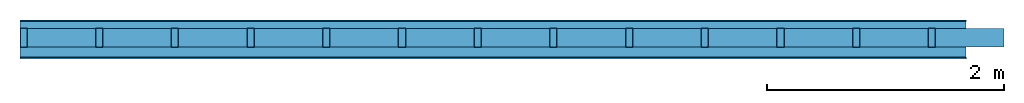
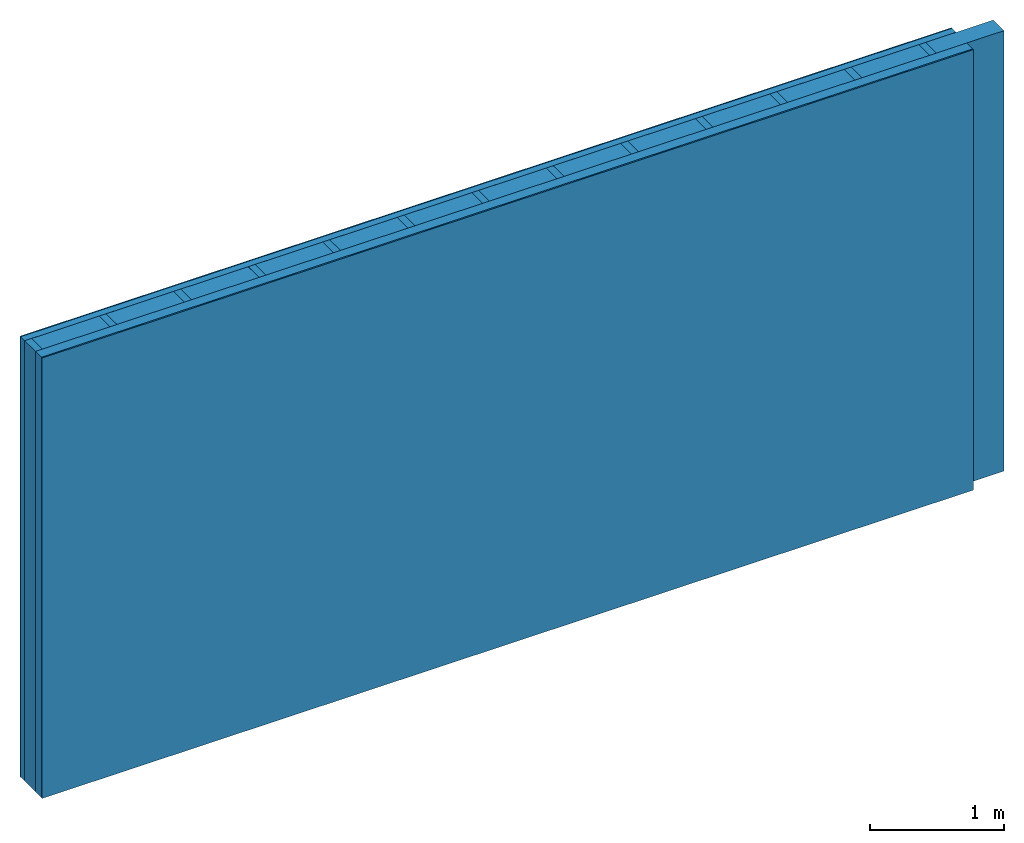
# One storey: 4 plates, 2 members, 1 element without a shape of its own.
"""IFC4 building model written with IfcOpenShell, lengths in metres."""

from ifc_helpers import new_model, si_unit, derived_unit, direction, frame, frame_2d, origin, origin_with_axes, place, context, project, spatial, rectangle, extrude, material, layer, layer_set, type_object, element, aggregate, save


model = new_model("IFC4")

# Units and contexts
plan_context = context("Plan", 3, precision=1e-05, world=origin(), true_north=direction((0.0, 1.0)))
model_context = context("Model", 3, precision=1e-05, world=origin(), true_north=direction((0.0, 1.0)))
ifc_project = project(units=[si_unit("LENGTHUNIT", "METRE"), derived_unit("SOUNDPRESSUREUNIT", [(si_unit("PRESSUREUNIT", "PASCAL", prefix="MICRO"), 0)]), si_unit("ENERGYUNIT", "JOULE", prefix="MEGA"), si_unit("MASSUNIT", "GRAM", prefix="KILO"), derived_unit("THERMALTRANSMITTANCEUNIT", [(si_unit("POWERUNIT", "WATT"), 1), (si_unit("AREAUNIT", "SQUARE_METRE"), -1), (si_unit("THERMODYNAMICTEMPERATUREUNIT", "KELVIN"), -1)]), derived_unit("AREADENSITYUNIT", [(si_unit("MASSUNIT", "GRAM", prefix="KILO"), 1), (si_unit("AREAUNIT", "SQUARE_METRE"), -1)]), derived_unit("USERDEFINED", [(si_unit("ENERGYUNIT", "JOULE", prefix="MEGA"), 1), (si_unit("AREAUNIT", "SQUARE_METRE"), -1)])], contexts=[plan_context, model_context])

# Site, building, storey
site = spatial("IfcSite", under=ifc_project)
building_placement = place(None, origin())
building = spatial("IfcBuilding", under=site, at=building_placement)
storey_placement = place(building_placement, origin())
storey = spatial("IfcBuildingStorey", under=building, at=storey_placement)

# Wall, members, plates
ifc_material_1 = material(Category="04.011")
ifc_layer_1 = layer(ifc_material_1, 0.01, Name="Surface 1")
ifc_material_2 = material(Category="10.009")
ifc_layer_2 = layer(ifc_material_2, 0.06, Name="outside 1st layer")
ifc_material_3 = material(Name="of the art")
ifc_layer_3 = layer(ifc_material_3, 0.0, Name="Bond")
ifc_layer_4 = layer(None, 0.16, Name="Support")
ifc_layer_5 = layer(ifc_material_3, 0.0, Name="Bond")
ifc_material_4 = material(Name="Solid timber panel")
ifc_layer_6 = layer(ifc_material_4, 0.087, Name="1st layer")
ifc_material_5 = material(Name="Plasterboard type A", Category="03.008")
ifc_layer_7 = layer(ifc_material_5, 0.0125, Name="Covering 1st layer")
ifc_material_6 = material(Name="joints", Category="04.017")
ifc_layer_8 = layer(ifc_material_6, 0.0, Name="Surface")
ifc_layer_set = layer_set([ifc_layer_1, ifc_layer_2, ifc_layer_3, ifc_layer_4, ifc_layer_5, ifc_layer_6, ifc_layer_7, ifc_layer_8])
wall_type = type_object("IfcWallType", Name="D0980", PredefinedType="NOTDEFINED", material=ifc_layer_set)
wall_placement = place(None, frame((0.0, 0.0, 0.0), z_axis=(0.0, -1.0, 0.0), x_axis=(1.0, 0.0, 0.0)))
wall = element("IfcWall", 1, at=wall_placement, inside=storey, type_object=wall_type, material=ifc_layer_set, Name="Wall #1")
ifc_material_7 = material()
member_1_placement = place(wall_placement, origin())
member_1 = element("IfcMember", 2, at=member_1_placement, material=ifc_material_7, Name="Support", context=plan_context, shape_type="SweptSolid", body=[
    extrude(rectangle(XDim=0.06, YDim=0.16, at=frame_2d((0.03, 0.08), x_axis=(1.0, 0.0))), frame((0.0, 4.0, 0.07), z_axis=(0.0, -1.0, 0.0), x_axis=(1.0, 0.0, 0.0)), (0.0, 0.0, 1.0), 4.0),
    extrude(rectangle(XDim=0.06, YDim=0.16, at=frame_2d((0.03, 0.08), x_axis=(1.0, 0.0))), frame((0.64, 4.0, 0.07), z_axis=(0.0, -1.0, 0.0), x_axis=(1.0, 0.0, 0.0)), (0.0, 0.0, 1.0), 4.0),
    extrude(rectangle(XDim=0.06, YDim=0.16, at=frame_2d((0.03, 0.08), x_axis=(1.0, 0.0))), frame((1.28, 4.0, 0.07), z_axis=(0.0, -1.0, 0.0), x_axis=(1.0, 0.0, 0.0)), (0.0, 0.0, 1.0), 4.0),
    extrude(rectangle(XDim=0.06, YDim=0.16, at=frame_2d((0.03, 0.08), x_axis=(1.0, 0.0))), frame((1.92, 4.0, 0.07), z_axis=(0.0, -1.0, 0.0), x_axis=(1.0, 0.0, 0.0)), (0.0, 0.0, 1.0), 4.0),
    extrude(rectangle(XDim=0.06, YDim=0.16, at=frame_2d((0.03, 0.08), x_axis=(1.0, 0.0))), frame((2.56, 4.0, 0.07), z_axis=(0.0, -1.0, 0.0), x_axis=(1.0, 0.0, 0.0)), (0.0, 0.0, 1.0), 4.0),
    extrude(rectangle(XDim=0.06, YDim=0.16, at=frame_2d((0.03, 0.08), x_axis=(1.0, 0.0))), frame((3.2, 4.0, 0.07), z_axis=(0.0, -1.0, 0.0), x_axis=(1.0, 0.0, 0.0)), (0.0, 0.0, 1.0), 4.0),
    extrude(rectangle(XDim=0.06, YDim=0.16, at=frame_2d((0.03, 0.08), x_axis=(1.0, 0.0))), frame((3.84, 4.0, 0.07), z_axis=(0.0, -1.0, 0.0), x_axis=(1.0, 0.0, 0.0)), (0.0, 0.0, 1.0), 4.0),
    extrude(rectangle(XDim=0.06, YDim=0.16, at=frame_2d((0.03, 0.08), x_axis=(1.0, 0.0))), frame((4.48, 4.0, 0.07), z_axis=(0.0, -1.0, 0.0), x_axis=(1.0, 0.0, 0.0)), (0.0, 0.0, 1.0), 4.0),
    extrude(rectangle(XDim=0.06, YDim=0.16, at=frame_2d((0.03, 0.08), x_axis=(1.0, 0.0))), frame((5.12, 4.0, 0.07), z_axis=(0.0, -1.0, 0.0), x_axis=(1.0, 0.0, 0.0)), (0.0, 0.0, 1.0), 4.0),
    extrude(rectangle(XDim=0.06, YDim=0.16, at=frame_2d((0.03, 0.08), x_axis=(1.0, 0.0))), frame((5.76, 4.0, 0.07), z_axis=(0.0, -1.0, 0.0), x_axis=(1.0, 0.0, 0.0)), (0.0, 0.0, 1.0), 4.0),
    extrude(rectangle(XDim=0.06, YDim=0.16, at=frame_2d((0.03, 0.08), x_axis=(1.0, 0.0))), frame((6.4, 4.0, 0.07), z_axis=(0.0, -1.0, 0.0), x_axis=(1.0, 0.0, 0.0)), (0.0, 0.0, 1.0), 4.0),
    extrude(rectangle(XDim=0.06, YDim=0.16, at=frame_2d((0.03, 0.08), x_axis=(1.0, 0.0))), frame((7.04, 4.0, 0.07), z_axis=(0.0, -1.0, 0.0), x_axis=(1.0, 0.0, 0.0)), (0.0, 0.0, 1.0), 4.0),
    extrude(rectangle(XDim=0.06, YDim=0.16, at=frame_2d((0.03, 0.08), x_axis=(1.0, 0.0))), frame((7.68, 4.0, 0.07), z_axis=(0.0, -1.0, 0.0), x_axis=(1.0, 0.0, 0.0)), (0.0, 0.0, 1.0), 4.0),
])
ifc_material_8 = material()
member_2_placement = place(wall_placement, origin())
member_2 = element("IfcMember", 3, at=member_2_placement, material=ifc_material_8, Name="Cavity", context=plan_context, shape_type="SweptSolid", body=[
    extrude(rectangle(XDim=0.58, YDim=0.16, at=frame_2d((0.29, 0.08), x_axis=(1.0, 0.0))), frame((0.06, 4.0, 0.07), z_axis=(0.0, -1.0, 0.0), x_axis=(1.0, 0.0, 0.0)), (0.0, 0.0, 1.0), 4.0),
    extrude(rectangle(XDim=0.58, YDim=0.16, at=frame_2d((0.29, 0.08), x_axis=(1.0, 0.0))), frame((0.7, 4.0, 0.07), z_axis=(0.0, -1.0, 0.0), x_axis=(1.0, 0.0, 0.0)), (0.0, 0.0, 1.0), 4.0),
    extrude(rectangle(XDim=0.58, YDim=0.16, at=frame_2d((0.29, 0.08), x_axis=(1.0, 0.0))), frame((1.34, 4.0, 0.07), z_axis=(0.0, -1.0, 0.0), x_axis=(1.0, 0.0, 0.0)), (0.0, 0.0, 1.0), 4.0),
    extrude(rectangle(XDim=0.58, YDim=0.16, at=frame_2d((0.29, 0.08), x_axis=(1.0, 0.0))), frame((1.98, 4.0, 0.07), z_axis=(0.0, -1.0, 0.0), x_axis=(1.0, 0.0, 0.0)), (0.0, 0.0, 1.0), 4.0),
    extrude(rectangle(XDim=0.58, YDim=0.16, at=frame_2d((0.29, 0.08), x_axis=(1.0, 0.0))), frame((2.62, 4.0, 0.07), z_axis=(0.0, -1.0, 0.0), x_axis=(1.0, 0.0, 0.0)), (0.0, 0.0, 1.0), 4.0),
    extrude(rectangle(XDim=0.58, YDim=0.16, at=frame_2d((0.29, 0.08), x_axis=(1.0, 0.0))), frame((3.26, 4.0, 0.07), z_axis=(0.0, -1.0, 0.0), x_axis=(1.0, 0.0, 0.0)), (0.0, 0.0, 1.0), 4.0),
    extrude(rectangle(XDim=0.58, YDim=0.16, at=frame_2d((0.29, 0.08), x_axis=(1.0, 0.0))), frame((3.9, 4.0, 0.07), z_axis=(0.0, -1.0, 0.0), x_axis=(1.0, 0.0, 0.0)), (0.0, 0.0, 1.0), 4.0),
    extrude(rectangle(XDim=0.58, YDim=0.16, at=frame_2d((0.29, 0.08), x_axis=(1.0, 0.0))), frame((4.54, 4.0, 0.07), z_axis=(0.0, -1.0, 0.0), x_axis=(1.0, 0.0, 0.0)), (0.0, 0.0, 1.0), 4.0),
    extrude(rectangle(XDim=0.58, YDim=0.16, at=frame_2d((0.29, 0.08), x_axis=(1.0, 0.0))), frame((5.18, 4.0, 0.07), z_axis=(0.0, -1.0, 0.0), x_axis=(1.0, 0.0, 0.0)), (0.0, 0.0, 1.0), 4.0),
    extrude(rectangle(XDim=0.58, YDim=0.16, at=frame_2d((0.29, 0.08), x_axis=(1.0, 0.0))), frame((5.82, 4.0, 0.07), z_axis=(0.0, -1.0, 0.0), x_axis=(1.0, 0.0, 0.0)), (0.0, 0.0, 1.0), 4.0),
    extrude(rectangle(XDim=0.58, YDim=0.16, at=frame_2d((0.29, 0.08), x_axis=(1.0, 0.0))), frame((6.46, 4.0, 0.07), z_axis=(0.0, -1.0, 0.0), x_axis=(1.0, 0.0, 0.0)), (0.0, 0.0, 1.0), 4.0),
    extrude(rectangle(XDim=0.58, YDim=0.16, at=frame_2d((0.29, 0.08), x_axis=(1.0, 0.0))), frame((7.1, 4.0, 0.07), z_axis=(0.0, -1.0, 0.0), x_axis=(1.0, 0.0, 0.0)), (0.0, 0.0, 1.0), 4.0),
    extrude(rectangle(XDim=0.58, YDim=0.16, at=frame_2d((0.29, 0.08), x_axis=(1.0, 0.0))), frame((7.74, 4.0, 0.07), z_axis=(0.0, -1.0, 0.0), x_axis=(1.0, 0.0, 0.0)), (0.0, 0.0, 1.0), 4.0),
])
plate_1_placement = place(wall_placement, origin())
plate_1 = element("IfcPlate", 4, at=plate_1_placement, material=ifc_material_1, Name="Surface 1", context=plan_context, shape_type="SweptSolid", body=[
    extrude(rectangle(XDim=8.0, YDim=4.0, at=frame_2d((4.0, 2.0), x_axis=(1.0, 0.0))), origin_with_axes(), (0.0, 0.0, 1.0), 0.01),
])
plate_2_placement = place(wall_placement, origin())
plate_2 = element("IfcPlate", 5, at=plate_2_placement, material=ifc_material_2, Name="outside 1st layer", context=plan_context, shape_type="SweptSolid", body=[
    extrude(rectangle(XDim=8.0, YDim=4.0, at=frame_2d((4.0, 2.0), x_axis=(1.0, 0.0))), frame((0.0, 0.0, 0.01), z_axis=(0.0, 0.0, 1.0), x_axis=(1.0, 0.0, 0.0)), (0.0, 0.0, 1.0), 0.06),
])
plate_3_placement = place(wall_placement, origin())
plate_3 = element("IfcPlate", 6, at=plate_3_placement, material=ifc_material_4, Name="1st layer", context=plan_context, shape_type="SweptSolid", body=[
    extrude(rectangle(XDim=8.0, YDim=4.0, at=frame_2d((4.0, 2.0), x_axis=(1.0, 0.0))), frame((0.0, 0.0, 0.23), z_axis=(0.0, 0.0, 1.0), x_axis=(1.0, 0.0, 0.0)), (0.0, 0.0, 1.0), 0.087),
])
plate_4_placement = place(wall_placement, origin())
plate_4 = element("IfcPlate", 7, at=plate_4_placement, material=ifc_material_5, Name="Covering 1st layer", context=plan_context, shape_type="SweptSolid", body=[
    extrude(rectangle(XDim=8.0, YDim=4.0, at=frame_2d((4.0, 2.0), x_axis=(1.0, 0.0))), frame((0.0, 0.0, 0.317), z_axis=(0.0, 0.0, 1.0), x_axis=(1.0, 0.0, 0.0)), (0.0, 0.0, 1.0), 0.0125),
])
aggregate(wall, [plate_1, plate_2, member_1, member_2, plate_3, plate_4])

save(model, "model.ifc")
